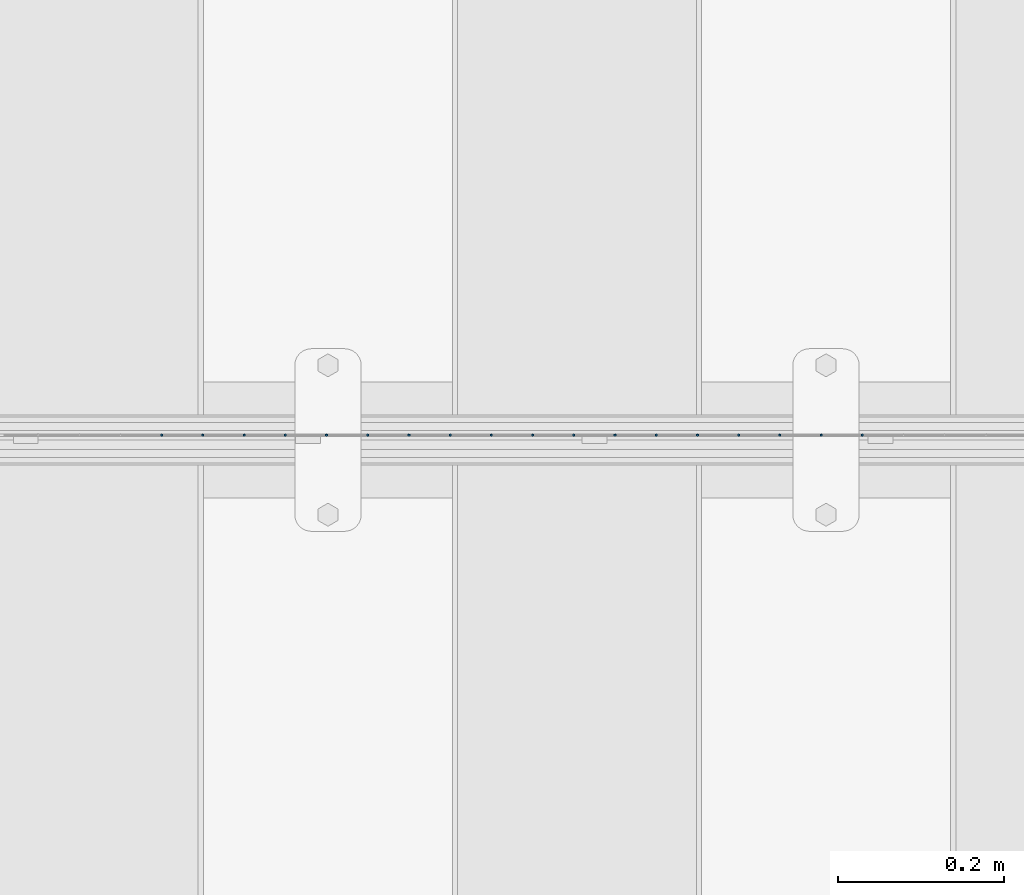
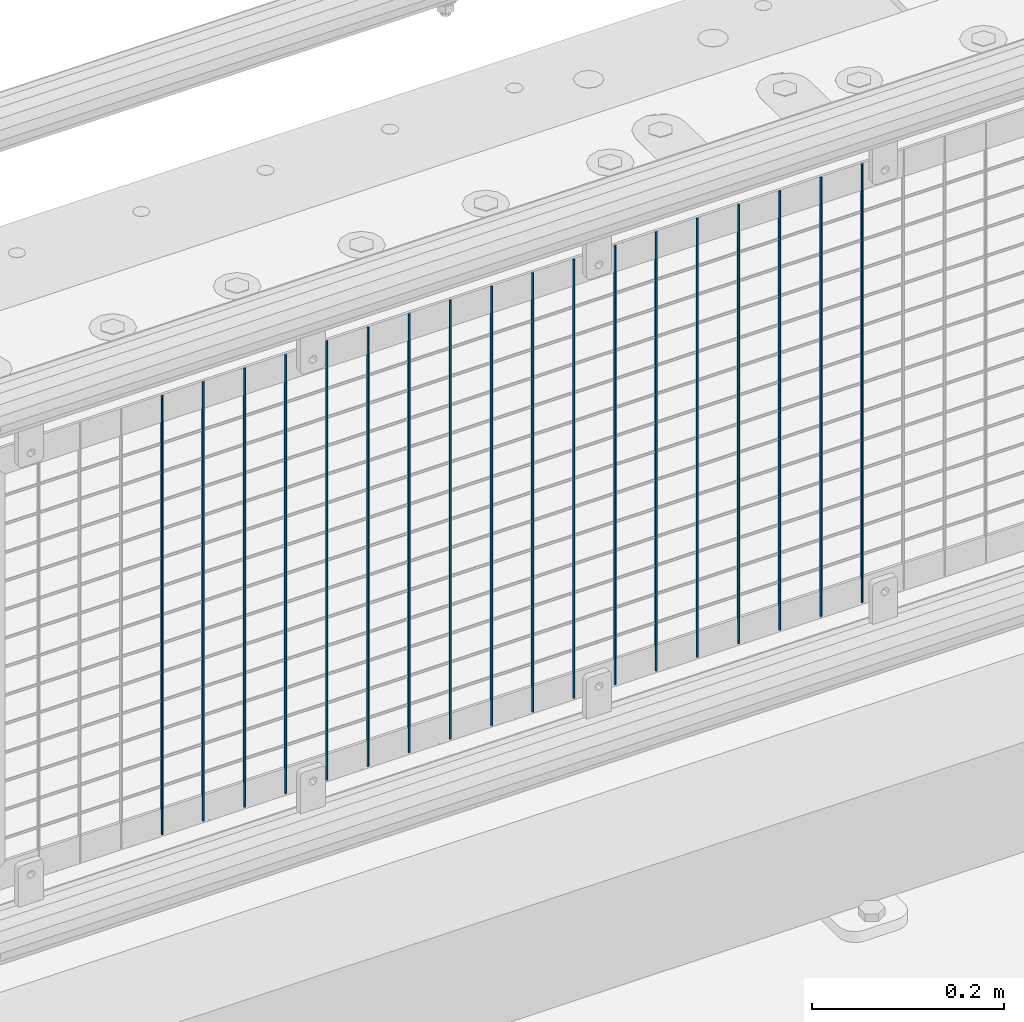
# One storey, part 76 of 247: 18 columns.
"""IFC2X3 building model written with IfcOpenShell, lengths in millimetres."""

import ifcopenshell
import ifcopenshell.guid

model = None  # the IFC model being written
_history = None  # IfcOwnerHistory: only IFC2X3 demands one
_inside = {}  # id of a spatial element -> (the spatial element, [elements in it])
_under = {}  # id of a project, library or spatial element -> (it, [spatial elements below it])
_declared = {}  # id of a project -> (the project, [libraries it declares])
_typed = {}  # id of a type object -> (the type object, [elements of that type])
_made_of = {}  # id of a material, layer set ... -> (it, [elements and type objects made of it])


def new_model(schema):
    """Start an empty IFC model of exactly this schema.

    Asked for "IFC4X3", IfcOpenShell would pick the latest addendum, in which some entities
    have other attributes; the version numbers below select the first issue.
    IFC2X3 requires an IfcOwnerHistory on every rooted entity: one is made here for all.
    """
    global model, _history
    if schema == "IFC4X3":
        model = ifcopenshell.file(schema_version=(4, 3, 0, 0))
    else:
        model = ifcopenshell.file(schema=schema)
    _inside.clear()
    _under.clear()
    _declared.clear()
    _typed.clear()
    _made_of.clear()
    _history = None
    if model.schema == "IFC2X3":
        org = make("IfcOrganization", Name="unknown")
        user = make(
            "IfcPersonAndOrganization",
            ThePerson=make("IfcPerson", FamilyName="unknown"),
            TheOrganization=org,
        )
        app = make(
            "IfcApplication",
            ApplicationDeveloper=org,
            Version="unknown",
            ApplicationFullName="unknown",
            ApplicationIdentifier="unknown",
        )
        _history = make(
            "IfcOwnerHistory",
            OwningUser=user,
            OwningApplication=app,
            ChangeAction="ADDED",
            CreationDate=0,
        )
    return model


def make(cls, **values):
    """One entity of the class cls with the attributes given. An attribute that is None is left unset."""
    return model.create_entity(
        cls, **{name: value for name, value in values.items() if value is not None}
    )


def rooted(cls, **values):
    """An entity with a GlobalId (a new one), such as an element, a storey or a relation."""
    return make(cls, GlobalId=ifcopenshell.guid.new(), OwnerHistory=_history, **values)


def si_unit(unit_type, name, prefix=None):
    """IfcSIUnit, for example si_unit("LENGTHUNIT", "METRE", prefix="MILLI")."""
    return make("IfcSIUnit", UnitType=unit_type, Prefix=prefix, Name=name)


def assignment(units):
    """IfcUnitAssignment: the units of a project."""
    return None if units is None else make("IfcUnitAssignment", Units=units)


def point(xyz):
    """IfcCartesianPoint."""
    return None if xyz is None else make("IfcCartesianPoint", Coordinates=xyz)


def direction(xyz):
    """IfcDirection."""
    return None if xyz is None else make("IfcDirection", DirectionRatios=xyz)


def frame(location, z_axis=None, x_axis=None):
    """IfcAxis2Placement3D, a coordinate frame: its origin and axes. An axis left out is left unset."""
    return make(
        "IfcAxis2Placement3D",
        Location=point(location),
        Axis=direction(z_axis),
        RefDirection=direction(x_axis),
    )


def origin_with_axes():
    """The frame at (0, 0, 0) with the z axis (0, 0, 1) and the x axis (1, 0, 0) written out."""
    return frame((0.0, 0.0, 0.0), z_axis=(0.0, 0.0, 1.0), x_axis=(1.0, 0.0, 0.0))


def place(relative_to, where):
    """IfcLocalPlacement: puts the frame where relative to a parent placement (None: the world)."""
    return make(
        "IfcLocalPlacement", PlacementRelTo=relative_to, RelativePlacement=where
    )


def context(
    kind, dimensions, precision=None, world=None, true_north=None, identifier=None
):
    """IfcGeometricRepresentationContext, for example the 3D "Model" context."""
    return make(
        "IfcGeometricRepresentationContext",
        ContextIdentifier=identifier,
        ContextType=kind,
        CoordinateSpaceDimension=dimensions,
        Precision=precision,
        WorldCoordinateSystem=world,
        TrueNorth=true_north,
    )


def subcontext(parent, identifier, kind, view, scale=None):
    """IfcGeometricRepresentationSubContext, for example "Body" below "Model"."""
    return make(
        "IfcGeometricRepresentationSubContext",
        ContextIdentifier=identifier,
        ContextType=kind,
        ParentContext=parent,
        TargetScale=scale,
        TargetView=view,
    )


def project(units=None, contexts=None):
    """IfcProject with its units and contexts."""
    return rooted(
        "IfcProject",
        Name="project",
        RepresentationContexts=contexts,
        UnitsInContext=assignment(units),
    )


def spatial(cls, under=None, at=None, **own):
    """A site, building, storey or space (cls), placed at a placement, below another one or the project."""
    s = rooted(cls, ObjectPlacement=at, **own)
    if under is not None:
        _under.setdefault(under.id(), (under, []))[1].append(s)
    return s


def faces_of(points, faces, orient=None, outer=None):
    """IfcFace entities. A face is a list of loops; a loop is a list of indices into points, from 0.

    orient and outer hold one flag for each loop. By default every Orientation is true, the
    first loop of a face is its IfcFaceOuterBound and the others are IfcFaceBound.
    """
    made = []
    for i, loops in enumerate(faces):
        bounds = []
        for j, loop in enumerate(loops):
            is_outer = j == 0 if outer is None else outer[i][j]
            bounds.append(
                make(
                    "IfcFaceOuterBound" if is_outer else "IfcFaceBound",
                    Bound=make("IfcPolyLoop", Polygon=[points[k] for k in loop]),
                    Orientation=True if orient is None else orient[i][j],
                )
            )
        made.append(make("IfcFace", Bounds=bounds))
    return made


def faceted_brep(points, faces, orient=None, outer=None, voids=None):
    """IfcFacetedBrep: a solid bounded by flat faces; with voids (closed shells), ...WithVoids."""
    shared = [point(p) for p in points]
    hull = make("IfcClosedShell", CfsFaces=faces_of(shared, faces, orient, outer))
    if voids is None:
        return make("IfcFacetedBrep", Outer=hull)
    return make(
        "IfcFacetedBrepWithVoids",
        Outer=hull,
        Voids=[
            make(cls, CfsFaces=faces_of(shared, fs, o, b)) for cls, fs, o, b in voids
        ],
    )


def shape(context_of_items, identifier, shape_type, items):
    """IfcShapeRepresentation: the items that make up one representation, for example the "Body"."""
    return make(
        "IfcShapeRepresentation",
        ContextOfItems=context_of_items,
        RepresentationIdentifier=identifier,
        RepresentationType=shape_type,
        Items=items,
    )


def material(Name=None, Category=None):
    """IfcMaterial."""
    return make("IfcMaterial", Name=Name, Category=Category)


def made_of(thing, what):
    """Note that an element or type object is made of a material, layer set ...; save() writes the relation."""
    if what is not None:
        _made_of.setdefault(what.id(), (what, []))[1].append(thing)
    return thing


def type_object(cls, material=None, **own):
    """A type object (cls), such as IfcWallType, which elements share."""
    return made_of(rooted(cls, **own), material)


def element(
    cls,
    number,
    at=None,
    inside=None,
    cuts=None,
    type_object=None,
    material=None,
    context=None,
    identifier="Body",
    shape_type=None,
    held_by="IfcProductDefinitionShape",
    body=None,
    shapes=None,
    **own,
):
    """One element of the class cls, such as IfcWall. Its Tag is "e" and its number.

    at: its placement. inside: the storey or other place that contains it. cuts: it is an
    opening in that element (IfcRelVoidsElement). A single representation is given by context,
    identifier, shape_type and body (its items); several are given by shapes. held_by: the class
    of the entity that holds the representations. save() writes the other relations.
    """
    e = rooted(cls, Tag="e%d" % number, ObjectPlacement=at, **own)
    if body is not None:
        shapes = [shape(context, identifier, shape_type, body)]
    if shapes is not None:
        e.Representation = make(held_by, Representations=shapes)
    if inside is not None:
        _inside.setdefault(inside.id(), (inside, []))[1].append(e)
    if cuts is not None:
        rooted(
            "IfcRelVoidsElement", RelatingBuildingElement=cuts, RelatedOpeningElement=e
        )
    if type_object is not None:
        _typed.setdefault(type_object.id(), (type_object, []))[1].append(e)
    return made_of(e, material)


def aggregate(whole, parts):
    """IfcRelAggregates: a whole, such as a stair, and the parts it consists of."""
    return rooted("IfcRelAggregates", RelatingObject=whole, RelatedObjects=parts)


def save(model, path):
    """Write the relations noted so far, then the file.

    IfcRelAggregates (storeys below a building ...), IfcRelContainedInSpatialStructure (elements
    in a storey), IfcRelDefinesByType, IfcRelAssociatesMaterial and IfcRelDeclares: one each for
    every whole, place, type object, material and project.
    """
    for whole, parts in _under.values():
        aggregate(whole, parts)
    for where, things in _inside.values():
        rooted(
            "IfcRelContainedInSpatialStructure",
            RelatedElements=things,
            RelatingStructure=where,
        )
    for kind, things in _typed.values():
        rooted("IfcRelDefinesByType", RelatedObjects=things, RelatingType=kind)
    for what, things in _made_of.values():
        rooted("IfcRelAssociatesMaterial", RelatedObjects=things, RelatingMaterial=what)
    for by, libraries in _declared.values():
        rooted("IfcRelDeclares", RelatingContext=by, RelatedDefinitions=libraries)
    model.write(path)


model = new_model("IFC2X3")

# Units and contexts
model_context = context("Model", 3, precision=1e-05, world=origin_with_axes())
body_context = subcontext(model_context, "Body", "Model", "MODEL_VIEW")
ifc_project = project(units=[si_unit("LENGTHUNIT", "METRE", prefix="MILLI"), si_unit("AREAUNIT", "SQUARE_METRE"), si_unit("VOLUMEUNIT", "CUBIC_METRE"), si_unit("MASSUNIT", "GRAM", prefix="KILO"), si_unit("TIMEUNIT", "SECOND"), si_unit("PLANEANGLEUNIT", "RADIAN"), si_unit("SOLIDANGLEUNIT", "STERADIAN"), si_unit("THERMODYNAMICTEMPERATUREUNIT", "DEGREE_CELSIUS"), si_unit("LUMINOUSINTENSITYUNIT", "LUMEN")], contexts=[model_context])

# Site, building, storey
site_placement = place(None, origin_with_axes())
site = spatial("IfcSite", under=ifc_project, at=site_placement, CompositionType="ELEMENT")
building_placement = place(site_placement, origin_with_axes())
building = spatial("IfcBuilding", under=site, at=building_placement, Name="Standard", CompositionType="ELEMENT")
storey_placement = place(building_placement, origin_with_axes())
storey = spatial("IfcBuildingStorey", under=building, at=storey_placement, Name="Undefined", CompositionType="ELEMENT", Elevation=0.0)

# Columns
ifc_material = material(Name="Misc_Undefined")
column_type = type_object("IfcColumnType", Name="D3", PredefinedType="NOTDEFINED")
for number, where, z_axis, x_axis in (
    (1, (4943.755, 7670.5, 353.02), (-1.0, 0.0, 0.0), (0.0, 0.0, 1.0)),
    (2, (4894.1, 7670.5, 353.02), (-1.0, 0.0, 0.0), (0.0, 0.0, 1.0)),
    (3, (4844.445, 7670.5, 353.02), (-1.0, 0.0, 0.0), (0.0, 0.0, 1.0)),
    (4, (4794.79, 7670.5, 353.02), (-1.0, 0.0, 0.0), (0.0, 0.0, 1.0)),
    (5, (4745.135, 7670.5, 353.02), (-1.0, 0.0, 0.0), (0.0, 0.0, 1.0)),
    (6, (4695.48, 7670.5, 353.02), (-1.0, 0.0, 0.0), (0.0, 0.0, 1.0)),
    (7, (4645.825, 7670.5, 353.02), (-1.0, 0.0, 0.0), (0.0, 0.0, 1.0)),
    (8, (4596.17, 7670.5, 353.02), (-1.0, 0.0, 0.0), (0.0, 0.0, 1.0)),
    (9, (4546.515, 7670.5, 353.02), (-1.0, 0.0, 0.0), (0.0, 0.0, 1.0)),
    (10, (4496.86, 7670.5, 353.02), (-1.0, 0.0, 0.0), (0.0, 0.0, 1.0)),
    (11, (4447.205, 7670.5, 353.02), (-1.0, 0.0, 0.0), (0.0, 0.0, 1.0)),
    (12, (4397.55, 7670.5, 353.02), (-1.0, 0.0, 0.0), (0.0, 0.0, 1.0)),
    (13, (4347.895, 7670.5, 353.02), (-1.0, 0.0, 0.0), (0.0, 0.0, 1.0)),
    (14, (4298.24, 7670.5, 353.02), (-1.0, 0.0, 0.0), (0.0, 0.0, 1.0)),
    (15, (4248.585, 7670.5, 353.02), (-1.0, 0.0, 0.0), (0.0, 0.0, 1.0)),
    (16, (4198.93, 7670.5, 353.02), (-1.0, 0.0, 0.0), (0.0, 0.0, 1.0)),
    (17, (4149.275, 7670.5, 353.02), (-1.0, 0.0, 0.0), (0.0, 0.0, 1.0)),
    (18, (4099.62, 7670.5, 353.02), (-1.0, 0.0, 0.0), (0.0, 0.0, 1.0)),
):
    element("IfcColumn", number, at=place(storey_placement, frame(where, z_axis=z_axis, x_axis=x_axis)), inside=storey, type_object=column_type, material=ifc_material, ObjectType="D3", context=body_context, shape_type="Brep", body=[
        faceted_brep([(1.81898940354586e-12, -1.5, -5.6843418860808e-14), (0.0, -0.75, -1.29903810567703), (560.0, -0.75, -1.29903810567703), (560.0, -1.5, 0.0), (0.0, 0.75, -1.29903810567703), (560.0, 0.75, -1.29903810567703), (1.81898940354586e-12, 1.5, -5.6843418860808e-14), (560.0, 1.5, 0.0), (0.0, 0.75, 1.29903810567703), (560.0, 0.75, 1.29903810567703), (0.0, -0.75, 1.29903810567703), (560.0, -0.75, 1.29903810567703)], [[[0, 1, 2, 3]], [[1, 4, 5, 2]], [[4, 6, 7, 5]], [[6, 8, 9, 7]], [[8, 10, 11, 9]], [[10, 0, 3, 11]], [[5, 7, 9, 11, 3, 2]], [[10, 8, 6, 4, 1, 0]]]),
    ])

save(model, "model.ifc")
